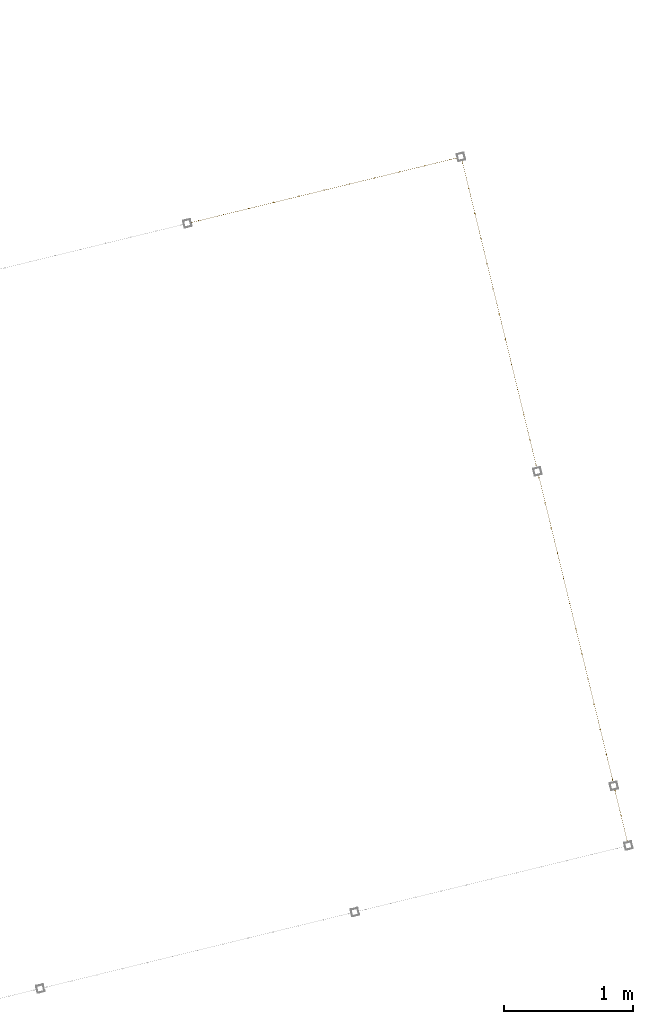
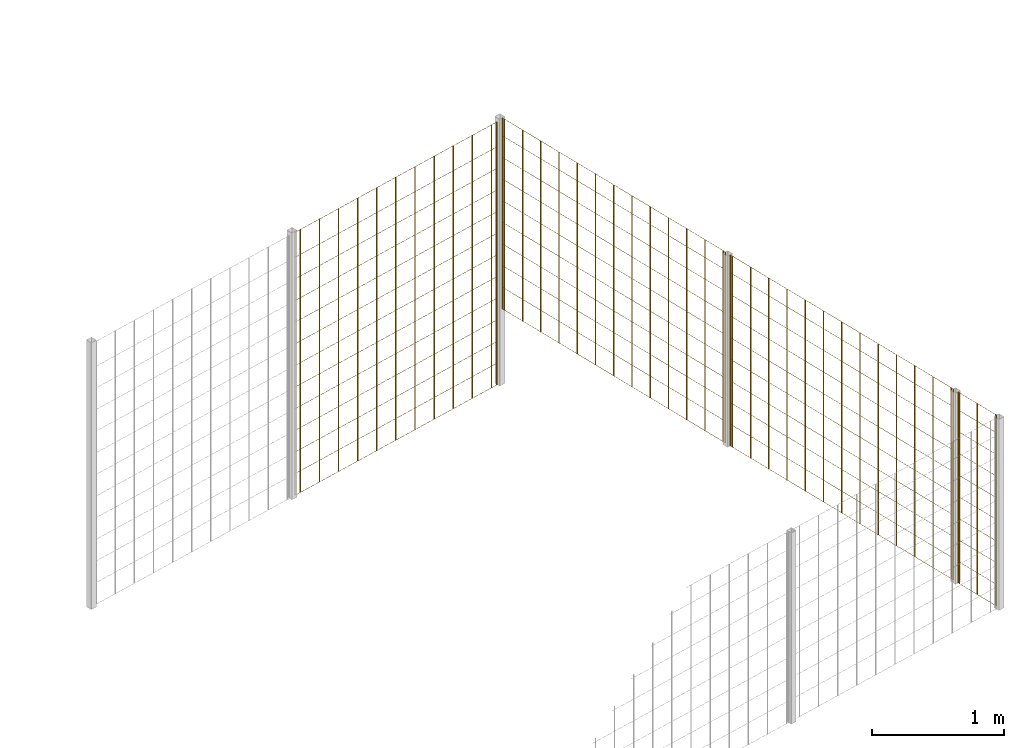
# One storey, part 9 of 10: 4 railings.
"""IFC2X3 building model written with IfcOpenShell, lengths in millimetres."""

from ifc_helpers import new_model, entity, si_unit, converted_unit, derived_unit, direction, frame, frame_2d, origin, origin_2d_with_axis, place, context, subcontext, project, spatial, rectangle, circle, extrude, material, material_list, element, save


model = new_model("IFC2X3")

# Units and contexts
model_context = context("Model", 3, precision=0.01, world=origin(), true_north=direction((6.12303176911189e-17, 1.0)))
body_context = subcontext(model_context, "Body", "Model", "MODEL_VIEW")
ifc_project = project(units=[si_unit("LENGTHUNIT", "METRE", prefix="MILLI"), si_unit("AREAUNIT", "SQUARE_METRE"), si_unit("VOLUMEUNIT", "CUBIC_METRE"), converted_unit("PLANEANGLEUNIT", "DEGREE", entity("IfcRatioMeasure", 0.0174532925199433), si_unit("PLANEANGLEUNIT", "RADIAN"), dimensions=[0, 0, 0, 0, 0, 0, 0]), si_unit("MASSUNIT", "GRAM", prefix="KILO"), derived_unit("MASSDENSITYUNIT", [(si_unit("MASSUNIT", "GRAM", prefix="KILO"), 1), (si_unit("LENGTHUNIT", "METRE"), -3)]), derived_unit("MOMENTOFINERTIAUNIT", [(si_unit("LENGTHUNIT", "METRE"), 4)]), si_unit("TIMEUNIT", "SECOND"), si_unit("FREQUENCYUNIT", "HERTZ"), si_unit("THERMODYNAMICTEMPERATUREUNIT", "DEGREE_CELSIUS"), derived_unit("THERMALTRANSMITTANCEUNIT", [(si_unit("MASSUNIT", "GRAM", prefix="KILO"), 1), (si_unit("THERMODYNAMICTEMPERATUREUNIT", "KELVIN"), -1), (si_unit("TIMEUNIT", "SECOND"), -3)]), derived_unit("VOLUMETRICFLOWRATEUNIT", [(si_unit("LENGTHUNIT", "METRE"), 3), (si_unit("TIMEUNIT", "SECOND"), -1)]), derived_unit("MASSFLOWRATEUNIT", [(si_unit("MASSUNIT", "GRAM", prefix="KILO"), 1), (si_unit("TIMEUNIT", "SECOND"), -1)]), derived_unit("ROTATIONALFREQUENCYUNIT", [(si_unit("TIMEUNIT", "SECOND"), -1)]), si_unit("ELECTRICCURRENTUNIT", "AMPERE"), si_unit("ELECTRICVOLTAGEUNIT", "VOLT"), si_unit("POWERUNIT", "WATT"), si_unit("FORCEUNIT", "NEWTON", prefix="KILO"), si_unit("ILLUMINANCEUNIT", "LUX"), si_unit("LUMINOUSFLUXUNIT", "LUMEN"), si_unit("LUMINOUSINTENSITYUNIT", "CANDELA"), derived_unit("USERDEFINED", [(si_unit("MASSUNIT", "GRAM", prefix="KILO"), -1), (si_unit("LENGTHUNIT", "METRE"), -2), (si_unit("TIMEUNIT", "SECOND"), 3), (si_unit("LUMINOUSFLUXUNIT", "LUMEN"), 1)]), derived_unit("LINEARVELOCITYUNIT", [(si_unit("LENGTHUNIT", "METRE"), 1), (si_unit("TIMEUNIT", "SECOND"), -1)]), si_unit("PRESSUREUNIT", "PASCAL"), derived_unit("USERDEFINED", [(si_unit("LENGTHUNIT", "METRE"), -2), (si_unit("MASSUNIT", "GRAM", prefix="KILO"), 1), (si_unit("TIMEUNIT", "SECOND"), -2)]), derived_unit("LINEARFORCEUNIT", [(si_unit("MASSUNIT", "GRAM", prefix="KILO"), 1), (si_unit("LENGTHUNIT", "METRE"), 1), (si_unit("TIMEUNIT", "SECOND"), -2), (si_unit("LENGTHUNIT", "METRE"), -1)]), derived_unit("PLANARFORCEUNIT", [(si_unit("MASSUNIT", "GRAM", prefix="KILO"), 1), (si_unit("LENGTHUNIT", "METRE"), 1), (si_unit("TIMEUNIT", "SECOND"), -2), (si_unit("LENGTHUNIT", "METRE"), -2)])], contexts=[model_context])

# Site, building, storey
site_placement = place(None, frame((19171.746869958, -72498.5768491146, 0.0), z_axis=(0.0, 0.0, 1.0), x_axis=(0.971695960795463, 0.236234967296933, 0.0)))
site = spatial("IfcSite", under=ifc_project, at=site_placement, CompositionType="ELEMENT")
building_placement = place(site_placement, origin())
building = spatial("IfcBuilding", under=site, at=building_placement, CompositionType="ELEMENT")
storey_placement = place(building_placement, origin())
storey = spatial("IfcBuildingStorey", under=building, at=storey_placement, CompositionType="ELEMENT", Elevation=0.0)

# Railings
ifc_material = material()
ifc_material_list_1 = material_list([ifc_material, ifc_material, ifc_material, ifc_material, ifc_material, ifc_material, ifc_material, ifc_material, ifc_material, ifc_material, ifc_material, ifc_material, ifc_material, ifc_material, ifc_material, ifc_material, ifc_material, ifc_material, ifc_material, ifc_material, ifc_material, ifc_material, ifc_material, ifc_material, ifc_material, ifc_material])
railing_1_placement = place(storey_placement, frame((7724.41250000003, 5593.41249999997, 0.0)))
element("IfcRailing", 1, at=railing_1_placement, inside=storey, material=ifc_material_list_1, PredefinedType="NOTDEFINED", context=body_context, shape_type="SweptSolid", body=[
    extrude(circle(Radius=5.0, at=origin_2d_with_axis()), frame((2063.08749999999, 6.58749999999959, 2.0), z_axis=(0.0, 0.0, 1.0), x_axis=(0.0, 1.0, 0.0)), (0.0, 0.0, 1.0), 2428.0),
    extrude(circle(Radius=5.0, at=origin_2d_with_axis()), frame((1863.08749999999, 6.58750000000067, 2.0), z_axis=(0.0, 0.0, 1.0), x_axis=(0.0, 1.0, 0.0)), (0.0, 0.0, 1.0), 2428.0),
    extrude(circle(Radius=5.0, at=origin_2d_with_axis()), frame((1663.08749999999, 6.58750000000067, 2.0), z_axis=(0.0, 0.0, 1.0), x_axis=(0.0, 1.0, 0.0)), (0.0, 0.0, 1.0), 2428.0),
    extrude(circle(Radius=5.0, at=origin_2d_with_axis()), frame((1463.08749999999, 6.58750000000175, 2.0), z_axis=(0.0, 0.0, 1.0), x_axis=(0.0, 1.0, 0.0)), (0.0, 0.0, 1.0), 2428.0),
    extrude(circle(Radius=5.0, at=origin_2d_with_axis()), frame((1263.08749999999, 6.58750000000175, 2.0), z_axis=(0.0, 0.0, 1.0), x_axis=(0.0, 1.0, 0.0)), (0.0, 0.0, 1.0), 2428.0),
    extrude(circle(Radius=5.0, at=origin_2d_with_axis()), frame((1063.08749999999, 6.58750000000283, 2.0), z_axis=(0.0, 0.0, 1.0), x_axis=(0.0, 1.0, 0.0)), (0.0, 0.0, 1.0), 2428.0),
    extrude(circle(Radius=5.0, at=origin_2d_with_axis()), frame((863.087499999992, 6.58750000000392, 2.0), z_axis=(0.0, 0.0, 1.0), x_axis=(0.0, 1.0, 0.0)), (0.0, 0.0, 1.0), 2428.0),
    extrude(circle(Radius=5.0, at=origin_2d_with_axis()), frame((663.087499999991, 6.58750000000392, 2.0), z_axis=(0.0, 0.0, 1.0), x_axis=(0.0, 1.0, 0.0)), (0.0, 0.0, 1.0), 2428.0),
    extrude(circle(Radius=5.0, at=origin_2d_with_axis()), frame((463.087499999992, 6.587500000005, 2.0), z_axis=(0.0, 0.0, 1.0), x_axis=(0.0, 1.0, 0.0)), (0.0, 0.0, 1.0), 2428.0),
    extrude(circle(Radius=5.0, at=origin_2d_with_axis()), frame((263.087499999992, 6.587500000005, 2.0), z_axis=(0.0, 0.0, 1.0), x_axis=(0.0, 1.0, 0.0)), (0.0, 0.0, 1.0), 2428.0),
    extrude(circle(Radius=5.0, at=origin_2d_with_axis()), frame((63.0874999999922, 6.58750000000608, 2.0), z_axis=(0.0, 0.0, 1.0), x_axis=(0.0, 1.0, 0.0)), (0.0, 0.0, 1.0), 2428.0),
    extrude(circle(Radius=5.0, at=origin_2d_with_axis()), frame((2119.58749999998, 6.58749999999959, 2.0), z_axis=(0.0, 0.0, 1.0), x_axis=(0.0, 1.0, 0.0)), (0.0, 0.0, 1.0), 2428.0),
    extrude(circle(Radius=5.0, at=origin_2d_with_axis()), frame((6.58749999999959, 6.58750000000608, 2.0), z_axis=(0.0, 0.0, 1.0), x_axis=(0.0, 1.0, 0.0)), (0.0, 0.0, 1.0), 2428.0),
    extrude(rectangle(XDim=2112.99999999998, YDim=1.99999999999955, at=frame_2d((-5.6843418860808e-13, 0.0), x_axis=(1.0, 0.0))), frame((1063.08749999999, 5.58750000000306, 0.0)), (0.0, 0.0, 1.0), 2.00000000000043),
    extrude(rectangle(XDim=2112.99999999998, YDim=1.99999999999955, at=frame_2d((-5.6843418860808e-13, 0.0), x_axis=(1.0, 0.0))), frame((1063.08749999999, 5.58750000000306, 200.0)), (0.0, 0.0, 1.0), 2.00000000000043),
    extrude(rectangle(XDim=2112.99999999998, YDim=1.99999999999955, at=frame_2d((-5.6843418860808e-13, 0.0), x_axis=(1.0, 0.0))), frame((1063.08749999999, 5.58750000000306, 400.0)), (0.0, 0.0, 1.0), 2.00000000000043),
    extrude(rectangle(XDim=2112.99999999998, YDim=1.99999999999955, at=frame_2d((-5.6843418860808e-13, 0.0), x_axis=(1.0, 0.0))), frame((1063.08749999999, 5.58750000000306, 600.0)), (0.0, 0.0, 1.0), 2.00000000000043),
    extrude(rectangle(XDim=2112.99999999998, YDim=1.99999999999955, at=frame_2d((-5.6843418860808e-13, 0.0), x_axis=(1.0, 0.0))), frame((1063.08749999999, 5.58750000000306, 800.0)), (0.0, 0.0, 1.0), 2.00000000000036),
    extrude(rectangle(XDim=2112.99999999998, YDim=1.99999999999955, at=frame_2d((-5.6843418860808e-13, 0.0), x_axis=(1.0, 0.0))), frame((1063.08749999999, 5.58750000000306, 1000.0)), (0.0, 0.0, 1.0), 2.00000000000036),
    extrude(rectangle(XDim=2112.99999999998, YDim=1.99999999999955, at=frame_2d((-5.6843418860808e-13, 0.0), x_axis=(1.0, 0.0))), frame((1063.08749999999, 5.58750000000306, 1200.0)), (0.0, 0.0, 1.0), 2.00000000000036),
    extrude(rectangle(XDim=2112.99999999998, YDim=1.99999999999955, at=frame_2d((-5.6843418860808e-13, 0.0), x_axis=(1.0, 0.0))), frame((1063.08749999999, 5.58750000000306, 1400.0)), (0.0, 0.0, 1.0), 2.00000000000036),
    extrude(rectangle(XDim=2112.99999999998, YDim=1.99999999999955, at=frame_2d((-5.6843418860808e-13, 0.0), x_axis=(1.0, 0.0))), frame((1063.08749999999, 5.58750000000306, 1600.0)), (0.0, 0.0, 1.0), 2.00000000000036),
    extrude(rectangle(XDim=2112.99999999998, YDim=1.99999999999955, at=frame_2d((-5.6843418860808e-13, 0.0), x_axis=(1.0, 0.0))), frame((1063.08749999999, 5.58750000000306, 1800.0)), (0.0, 0.0, 1.0), 2.00000000000036),
    extrude(rectangle(XDim=2112.99999999998, YDim=1.99999999999955, at=frame_2d((-5.6843418860808e-13, 0.0), x_axis=(1.0, 0.0))), frame((1063.08749999999, 5.58750000000306, 2000.0)), (0.0, 0.0, 1.0), 2.00000000000036),
    extrude(rectangle(XDim=2112.99999999998, YDim=1.99999999999955, at=frame_2d((-5.6843418860808e-13, 0.0), x_axis=(1.0, 0.0))), frame((1063.08749999999, 5.58750000000306, 2200.0)), (0.0, 0.0, 1.0), 2.00000000000036),
    extrude(rectangle(XDim=2112.99999999998, YDim=1.99999999999955, at=frame_2d((-5.6843418860808e-13, 0.0), x_axis=(1.0, 0.0))), frame((1063.08749999999, 5.58750000000306, 2430.0)), (0.0, 0.0, 1.0), 2.00000000000036),
])
ifc_material_list_2 = material_list([ifc_material, ifc_material, ifc_material, ifc_material, ifc_material, ifc_material, ifc_material, ifc_material, ifc_material, ifc_material, ifc_material, ifc_material, ifc_material, ifc_material, ifc_material, ifc_material, ifc_material, ifc_material, ifc_material, ifc_material, ifc_material, ifc_material, ifc_material, ifc_material, ifc_material])
railing_2_placement = place(storey_placement, frame((9868.41250000003, 619.512499999967, 700.0)))
element("IfcRailing", 2, at=railing_2_placement, inside=storey, material=ifc_material_list_2, PredefinedType="NOTDEFINED", context=body_context, shape_type="SweptSolid", body=[
    extrude(circle(Radius=5.0, at=origin_2d_with_axis()), frame((6.58750000000608, 2429.7875, 2.0), z_axis=(0.0, 0.0, 1.0), x_axis=(-1.0, 0.0, 0.0)), (0.0, 0.0, 1.0), 1763.0),
    extrude(circle(Radius=5.0, at=origin_2d_with_axis()), frame((6.58750000000608, 2229.7875, 2.0), z_axis=(0.0, 0.0, 1.0), x_axis=(-1.0, 0.0, 0.0)), (0.0, 0.0, 1.0), 1763.0),
    extrude(circle(Radius=5.0, at=origin_2d_with_axis()), frame((6.58750000000608, 2029.7875, 2.0), z_axis=(0.0, 0.0, 1.0), x_axis=(-1.0, 0.0, 0.0)), (0.0, 0.0, 1.0), 1763.0),
    extrude(circle(Radius=5.0, at=origin_2d_with_axis()), frame((6.58750000000392, 1829.7875, 2.0), z_axis=(0.0, 0.0, 1.0), x_axis=(-1.0, 0.0, 0.0)), (0.0, 0.0, 1.0), 1763.0),
    extrude(circle(Radius=5.0, at=origin_2d_with_axis()), frame((6.58750000000392, 1629.7875, 2.0), z_axis=(0.0, 0.0, 1.0), x_axis=(-1.0, 0.0, 0.0)), (0.0, 0.0, 1.0), 1763.0),
    extrude(circle(Radius=5.0, at=origin_2d_with_axis()), frame((6.58750000000392, 1429.7875, 2.0), z_axis=(0.0, 0.0, 1.0), x_axis=(-1.0, 0.0, 0.0)), (0.0, 0.0, 1.0), 1763.0),
    extrude(circle(Radius=5.0, at=origin_2d_with_axis()), frame((6.58750000000392, 1229.7875, 2.0), z_axis=(0.0, 0.0, 1.0), x_axis=(-1.0, 0.0, 0.0)), (0.0, 0.0, 1.0), 1763.0),
    extrude(circle(Radius=5.0, at=origin_2d_with_axis()), frame((6.58750000000392, 1029.7875, 2.0), z_axis=(0.0, 0.0, 1.0), x_axis=(-1.0, 0.0, 0.0)), (0.0, 0.0, 1.0), 1763.0),
    extrude(circle(Radius=5.0, at=origin_2d_with_axis()), frame((6.58750000000392, 829.7875, 2.0), z_axis=(0.0, 0.0, 1.0), x_axis=(-1.0, 0.0, 0.0)), (0.0, 0.0, 1.0), 1763.0),
    extrude(circle(Radius=5.0, at=origin_2d_with_axis()), frame((6.58750000000392, 629.7875, 2.0), z_axis=(0.0, 0.0, 1.0), x_axis=(-1.0, 0.0, 0.0)), (0.0, 0.0, 1.0), 1763.0),
    extrude(circle(Radius=5.0, at=origin_2d_with_axis()), frame((6.58750000000175, 429.7875, 2.0), z_axis=(0.0, 0.0, 1.0), x_axis=(-1.0, 0.0, 0.0)), (0.0, 0.0, 1.0), 1763.0),
    extrude(circle(Radius=5.0, at=origin_2d_with_axis()), frame((6.58750000000175, 229.7875, 2.0), z_axis=(0.0, 0.0, 1.0), x_axis=(-1.0, 0.0, 0.0)), (0.0, 0.0, 1.0), 1763.0),
    extrude(circle(Radius=5.0, at=origin_2d_with_axis()), frame((6.58750000000175, 29.7875000000004, 2.0), z_axis=(0.0, 0.0, 1.0), x_axis=(-1.0, 0.0, 0.0)), (0.0, 0.0, 1.0), 1763.0),
    extrude(circle(Radius=5.0, at=origin_2d_with_axis()), frame((6.58750000000608, 2452.9875, 2.0), z_axis=(0.0, 0.0, 1.0), x_axis=(-1.0, 0.0, 0.0)), (0.0, 0.0, 1.0), 1763.0),
    extrude(circle(Radius=5.0, at=origin_2d_with_axis()), frame((6.58750000000175, 6.58749999999999, 2.0), z_axis=(0.0, 0.0, 1.0), x_axis=(-1.0, 0.0, 0.0)), (0.0, 0.0, 1.0), 1763.0),
    extrude(rectangle(XDim=2446.4, YDim=1.99999999999955, at=frame_2d((-1.13686837721616e-13, 0.0), x_axis=(1.0, 0.0))), frame((7.58750000000369, 1229.7875, 0.0), z_axis=(0.0, 0.0, 1.0), x_axis=(0.0, 1.0, 0.0)), (0.0, 0.0, 1.0), 2.00000000000036),
    extrude(rectangle(XDim=2446.4, YDim=1.99999999999955, at=frame_2d((-1.13686837721616e-13, 0.0), x_axis=(1.0, 0.0))), frame((7.58750000000369, 1229.7875, 200.0), z_axis=(0.0, 0.0, 1.0), x_axis=(0.0, 1.0, 0.0)), (0.0, 0.0, 1.0), 2.00000000000036),
    extrude(rectangle(XDim=2446.4, YDim=1.99999999999955, at=frame_2d((-1.13686837721616e-13, 0.0), x_axis=(1.0, 0.0))), frame((7.58750000000369, 1229.7875, 400.0), z_axis=(0.0, 0.0, 1.0), x_axis=(0.0, 1.0, 0.0)), (0.0, 0.0, 1.0), 2.00000000000036),
    extrude(rectangle(XDim=2446.4, YDim=1.99999999999955, at=frame_2d((-1.13686837721616e-13, 0.0), x_axis=(1.0, 0.0))), frame((7.58750000000369, 1229.7875, 600.0), z_axis=(0.0, 0.0, 1.0), x_axis=(0.0, 1.0, 0.0)), (0.0, 0.0, 1.0), 2.00000000000036),
    extrude(rectangle(XDim=2446.4, YDim=1.99999999999955, at=frame_2d((-1.13686837721616e-13, 0.0), x_axis=(1.0, 0.0))), frame((7.58750000000369, 1229.7875, 800.0), z_axis=(0.0, 0.0, 1.0), x_axis=(0.0, 1.0, 0.0)), (0.0, 0.0, 1.0), 2.00000000000036),
    extrude(rectangle(XDim=2446.4, YDim=1.99999999999955, at=frame_2d((-1.13686837721616e-13, 0.0), x_axis=(1.0, 0.0))), frame((7.58750000000369, 1229.7875, 1000.0), z_axis=(0.0, 0.0, 1.0), x_axis=(0.0, 1.0, 0.0)), (0.0, 0.0, 1.0), 2.00000000000036),
    extrude(rectangle(XDim=2446.4, YDim=1.99999999999955, at=frame_2d((-1.13686837721616e-13, 0.0), x_axis=(1.0, 0.0))), frame((7.58750000000369, 1229.7875, 1200.0), z_axis=(0.0, 0.0, 1.0), x_axis=(0.0, 1.0, 0.0)), (0.0, 0.0, 1.0), 2.00000000000036),
    extrude(rectangle(XDim=2446.4, YDim=1.99999999999955, at=frame_2d((-1.13686837721616e-13, 0.0), x_axis=(1.0, 0.0))), frame((7.58750000000369, 1229.7875, 1400.0), z_axis=(0.0, 0.0, 1.0), x_axis=(0.0, 1.0, 0.0)), (0.0, 0.0, 1.0), 2.00000000000036),
    extrude(rectangle(XDim=2446.4, YDim=1.99999999999955, at=frame_2d((-1.13686837721616e-13, 0.0), x_axis=(1.0, 0.0))), frame((7.58750000000369, 1229.7875, 1600.0), z_axis=(0.0, 0.0, 1.0), x_axis=(0.0, 1.0, 0.0)), (0.0, 0.0, 1.0), 2.00000000000036),
    extrude(rectangle(XDim=2446.4, YDim=1.99999999999955, at=frame_2d((-1.13686837721616e-13, 0.0), x_axis=(1.0, 0.0))), frame((7.58750000000369, 1229.7875, 1765.0), z_axis=(0.0, 0.0, 1.0), x_axis=(0.0, 1.0, 0.0)), (0.0, 0.0, 1.0), 2.00000000000063),
])
ifc_material_list_3 = material_list([ifc_material, ifc_material, ifc_material, ifc_material, ifc_material, ifc_material, ifc_material, ifc_material, ifc_material, ifc_material, ifc_material, ifc_material, ifc_material, ifc_material, ifc_material, ifc_material, ifc_material, ifc_material, ifc_material, ifc_material, ifc_material, ifc_material, ifc_material, ifc_material, ifc_material])
railing_3_placement = place(storey_placement, frame((9868.41250000004, 3120.91249999997, 700.0)))
element("IfcRailing", 3, at=railing_3_placement, inside=storey, material=ifc_material_list_3, PredefinedType="NOTDEFINED", context=body_context, shape_type="SweptSolid", body=[
    extrude(circle(Radius=5.0, at=origin_2d_with_axis()), frame((6.58750000000608, 2429.0875, 2.0), z_axis=(0.0, 0.0, 1.0), x_axis=(-1.0, 0.0, 0.0)), (0.0, 0.0, 1.0), 1763.0),
    extrude(circle(Radius=5.0, at=origin_2d_with_axis()), frame((6.58750000000608, 2229.0875, 2.0), z_axis=(0.0, 0.0, 1.0), x_axis=(-1.0, 0.0, 0.0)), (0.0, 0.0, 1.0), 1763.0),
    extrude(circle(Radius=5.0, at=origin_2d_with_axis()), frame((6.58750000000608, 2029.0875, 2.0), z_axis=(0.0, 0.0, 1.0), x_axis=(-1.0, 0.0, 0.0)), (0.0, 0.0, 1.0), 1763.0),
    extrude(circle(Radius=5.0, at=origin_2d_with_axis()), frame((6.58750000000392, 1829.0875, 2.0), z_axis=(0.0, 0.0, 1.0), x_axis=(-1.0, 0.0, 0.0)), (0.0, 0.0, 1.0), 1763.0),
    extrude(circle(Radius=5.0, at=origin_2d_with_axis()), frame((6.58750000000392, 1629.0875, 2.0), z_axis=(0.0, 0.0, 1.0), x_axis=(-1.0, 0.0, 0.0)), (0.0, 0.0, 1.0), 1763.0),
    extrude(circle(Radius=5.0, at=origin_2d_with_axis()), frame((6.58750000000392, 1429.0875, 2.0), z_axis=(0.0, 0.0, 1.0), x_axis=(-1.0, 0.0, 0.0)), (0.0, 0.0, 1.0), 1763.0),
    extrude(circle(Radius=5.0, at=origin_2d_with_axis()), frame((6.58750000000392, 1229.0875, 2.0), z_axis=(0.0, 0.0, 1.0), x_axis=(-1.0, 0.0, 0.0)), (0.0, 0.0, 1.0), 1763.0),
    extrude(circle(Radius=5.0, at=origin_2d_with_axis()), frame((6.58750000000392, 1029.0875, 2.0), z_axis=(0.0, 0.0, 1.0), x_axis=(-1.0, 0.0, 0.0)), (0.0, 0.0, 1.0), 1763.0),
    extrude(circle(Radius=5.0, at=origin_2d_with_axis()), frame((6.58750000000392, 829.087500000001, 2.0), z_axis=(0.0, 0.0, 1.0), x_axis=(-1.0, 0.0, 0.0)), (0.0, 0.0, 1.0), 1763.0),
    extrude(circle(Radius=5.0, at=origin_2d_with_axis()), frame((6.58750000000392, 629.087500000001, 2.0), z_axis=(0.0, 0.0, 1.0), x_axis=(-1.0, 0.0, 0.0)), (0.0, 0.0, 1.0), 1763.0),
    extrude(circle(Radius=5.0, at=origin_2d_with_axis()), frame((6.58750000000175, 429.087500000001, 2.0), z_axis=(0.0, 0.0, 1.0), x_axis=(-1.0, 0.0, 0.0)), (0.0, 0.0, 1.0), 1763.0),
    extrude(circle(Radius=5.0, at=origin_2d_with_axis()), frame((6.58750000000175, 229.0875, 2.0), z_axis=(0.0, 0.0, 1.0), x_axis=(-1.0, 0.0, 0.0)), (0.0, 0.0, 1.0), 1763.0),
    extrude(circle(Radius=5.0, at=origin_2d_with_axis()), frame((6.58750000000175, 29.087500000001, 2.0), z_axis=(0.0, 0.0, 1.0), x_axis=(-1.0, 0.0, 0.0)), (0.0, 0.0, 1.0), 1763.0),
    extrude(circle(Radius=5.0, at=origin_2d_with_axis()), frame((6.58750000000608, 2451.5875, 2.0), z_axis=(0.0, 0.0, 1.0), x_axis=(-1.0, 0.0, 0.0)), (0.0, 0.0, 1.0), 1763.0),
    extrude(circle(Radius=5.0, at=origin_2d_with_axis()), frame((6.58750000000175, 6.58750000000013, 2.0), z_axis=(0.0, 0.0, 1.0), x_axis=(-1.0, 0.0, 0.0)), (0.0, 0.0, 1.0), 1763.0),
    extrude(rectangle(XDim=2445.0, YDim=1.99999999999955, at=frame_2d((2.27373675443232e-13, 0.0), x_axis=(1.0, 0.0))), frame((7.58750000000369, 1229.0875, 0.0), z_axis=(0.0, 0.0, 1.0), x_axis=(0.0, 1.0, 0.0)), (0.0, 0.0, 1.0), 2.00000000000036),
    extrude(rectangle(XDim=2445.0, YDim=1.99999999999955, at=frame_2d((2.27373675443232e-13, 0.0), x_axis=(1.0, 0.0))), frame((7.58750000000369, 1229.0875, 200.0), z_axis=(0.0, 0.0, 1.0), x_axis=(0.0, 1.0, 0.0)), (0.0, 0.0, 1.0), 2.00000000000036),
    extrude(rectangle(XDim=2445.0, YDim=1.99999999999955, at=frame_2d((2.27373675443232e-13, 0.0), x_axis=(1.0, 0.0))), frame((7.58750000000369, 1229.0875, 400.0), z_axis=(0.0, 0.0, 1.0), x_axis=(0.0, 1.0, 0.0)), (0.0, 0.0, 1.0), 2.00000000000036),
    extrude(rectangle(XDim=2445.0, YDim=1.99999999999955, at=frame_2d((2.27373675443232e-13, 0.0), x_axis=(1.0, 0.0))), frame((7.58750000000369, 1229.0875, 600.0), z_axis=(0.0, 0.0, 1.0), x_axis=(0.0, 1.0, 0.0)), (0.0, 0.0, 1.0), 2.00000000000036),
    extrude(rectangle(XDim=2445.0, YDim=1.99999999999955, at=frame_2d((2.27373675443232e-13, 0.0), x_axis=(1.0, 0.0))), frame((7.58750000000369, 1229.0875, 800.0), z_axis=(0.0, 0.0, 1.0), x_axis=(0.0, 1.0, 0.0)), (0.0, 0.0, 1.0), 2.00000000000036),
    extrude(rectangle(XDim=2445.0, YDim=1.99999999999955, at=frame_2d((2.27373675443232e-13, 0.0), x_axis=(1.0, 0.0))), frame((7.58750000000369, 1229.0875, 1000.0), z_axis=(0.0, 0.0, 1.0), x_axis=(0.0, 1.0, 0.0)), (0.0, 0.0, 1.0), 2.00000000000036),
    extrude(rectangle(XDim=2445.0, YDim=1.99999999999955, at=frame_2d((2.27373675443232e-13, 0.0), x_axis=(1.0, 0.0))), frame((7.58750000000369, 1229.0875, 1200.0), z_axis=(0.0, 0.0, 1.0), x_axis=(0.0, 1.0, 0.0)), (0.0, 0.0, 1.0), 2.00000000000036),
    extrude(rectangle(XDim=2445.0, YDim=1.99999999999955, at=frame_2d((2.27373675443232e-13, 0.0), x_axis=(1.0, 0.0))), frame((7.58750000000369, 1229.0875, 1400.0), z_axis=(0.0, 0.0, 1.0), x_axis=(0.0, 1.0, 0.0)), (0.0, 0.0, 1.0), 2.00000000000036),
    extrude(rectangle(XDim=2445.0, YDim=1.99999999999955, at=frame_2d((2.27373675443232e-13, 0.0), x_axis=(1.0, 0.0))), frame((7.58750000000369, 1229.0875, 1600.0), z_axis=(0.0, 0.0, 1.0), x_axis=(0.0, 1.0, 0.0)), (0.0, 0.0, 1.0), 2.00000000000036),
    extrude(rectangle(XDim=2445.0, YDim=1.99999999999955, at=frame_2d((2.27373675443232e-13, 0.0), x_axis=(1.0, 0.0))), frame((7.58750000000369, 1229.0875, 1765.0), z_axis=(0.0, 0.0, 1.0), x_axis=(0.0, 1.0, 0.0)), (0.0, 0.0, 1.0), 2.00000000000063),
])
ifc_material_list_4 = material_list([ifc_material, ifc_material, ifc_material, ifc_material, ifc_material, ifc_material, ifc_material, ifc_material, ifc_material, ifc_material, ifc_material, ifc_material, ifc_material, ifc_material, ifc_material])
railing_4_placement = place(storey_placement, frame((9868.41250000003, 145.912499999967, 700.0)))
element("IfcRailing", 4, at=railing_4_placement, inside=storey, material=ifc_material_list_4, PredefinedType="NOTDEFINED", context=body_context, shape_type="SweptSolid", body=[
    extrude(circle(Radius=5.0, at=frame_2d((0.0, 3.38395977905748e-14), x_axis=(1.0, 0.0))), frame((6.58750000000175, 16.5875000000004, 2.0)), (0.0, 0.0, 1.0), 1763.0),
    extrude(circle(Radius=5.0, at=origin_2d_with_axis()), frame((6.58750000000175, 216.587500000001, 2.0)), (0.0, 0.0, 1.0), 1763.0),
    extrude(circle(Radius=5.0, at=origin_2d_with_axis()), frame((6.58750000000175, 416.587500000001, 2.0)), (0.0, 0.0, 1.0), 1763.0),
    extrude(circle(Radius=5.0, at=frame_2d((0.0, 3.38395977905748e-14), x_axis=(1.0, 0.0))), frame((6.58750000000175, 6.58749999999994, 2.0)), (0.0, 0.0, 1.0), 1763.0),
    extrude(circle(Radius=5.0, at=origin_2d_with_axis()), frame((6.58750000000175, 426.587500000001, 2.0)), (0.0, 0.0, 1.0), 1763.0),
    extrude(rectangle(XDim=420.000000000001, YDim=1.99999999999955, at=origin_2d_with_axis()), frame((5.58750000000198, 216.587500000001, 0.0), z_axis=(0.0, 0.0, 1.0), x_axis=(0.0, -1.0, 0.0)), (0.0, 0.0, 1.0), 2.00000000000036),
    extrude(rectangle(XDim=420.000000000001, YDim=1.99999999999955, at=origin_2d_with_axis()), frame((5.58750000000198, 216.587500000001, 200.0), z_axis=(0.0, 0.0, 1.0), x_axis=(0.0, -1.0, 0.0)), (0.0, 0.0, 1.0), 2.00000000000036),
    extrude(rectangle(XDim=420.000000000001, YDim=1.99999999999955, at=origin_2d_with_axis()), frame((5.58750000000198, 216.587500000001, 400.0), z_axis=(0.0, 0.0, 1.0), x_axis=(0.0, -1.0, 0.0)), (0.0, 0.0, 1.0), 2.00000000000036),
    extrude(rectangle(XDim=420.000000000001, YDim=1.99999999999955, at=origin_2d_with_axis()), frame((5.58750000000198, 216.587500000001, 600.0), z_axis=(0.0, 0.0, 1.0), x_axis=(0.0, -1.0, 0.0)), (0.0, 0.0, 1.0), 2.00000000000036),
    extrude(rectangle(XDim=420.000000000001, YDim=1.99999999999955, at=origin_2d_with_axis()), frame((5.58750000000198, 216.587500000001, 800.0), z_axis=(0.0, 0.0, 1.0), x_axis=(0.0, -1.0, 0.0)), (0.0, 0.0, 1.0), 2.00000000000036),
    extrude(rectangle(XDim=420.000000000001, YDim=1.99999999999955, at=origin_2d_with_axis()), frame((5.58750000000198, 216.587500000001, 1000.0), z_axis=(0.0, 0.0, 1.0), x_axis=(0.0, -1.0, 0.0)), (0.0, 0.0, 1.0), 2.00000000000036),
    extrude(rectangle(XDim=420.000000000001, YDim=1.99999999999955, at=origin_2d_with_axis()), frame((5.58750000000198, 216.587500000001, 1200.0), z_axis=(0.0, 0.0, 1.0), x_axis=(0.0, -1.0, 0.0)), (0.0, 0.0, 1.0), 2.00000000000036),
    extrude(rectangle(XDim=420.000000000001, YDim=1.99999999999955, at=origin_2d_with_axis()), frame((5.58750000000198, 216.587500000001, 1400.0), z_axis=(0.0, 0.0, 1.0), x_axis=(0.0, -1.0, 0.0)), (0.0, 0.0, 1.0), 2.00000000000036),
    extrude(rectangle(XDim=420.000000000001, YDim=1.99999999999955, at=origin_2d_with_axis()), frame((5.58750000000198, 216.587500000001, 1600.0), z_axis=(0.0, 0.0, 1.0), x_axis=(0.0, -1.0, 0.0)), (0.0, 0.0, 1.0), 2.00000000000036),
    extrude(rectangle(XDim=420.000000000001, YDim=1.99999999999955, at=origin_2d_with_axis()), frame((5.58750000000198, 216.587500000001, 1765.0), z_axis=(0.0, 0.0, 1.0), x_axis=(0.0, -1.0, 0.0)), (0.0, 0.0, 1.0), 2.00000000000063),
])

save(model, "model.ifc")
